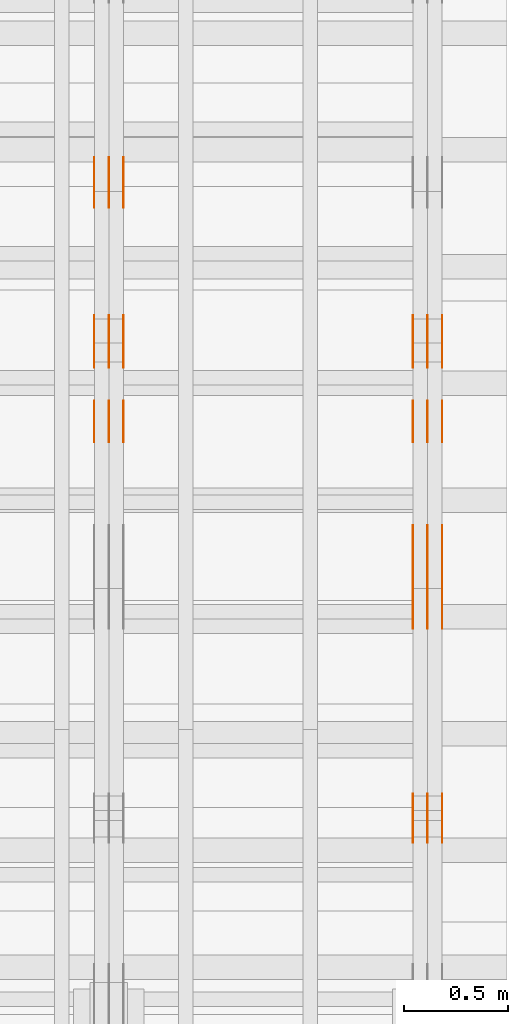
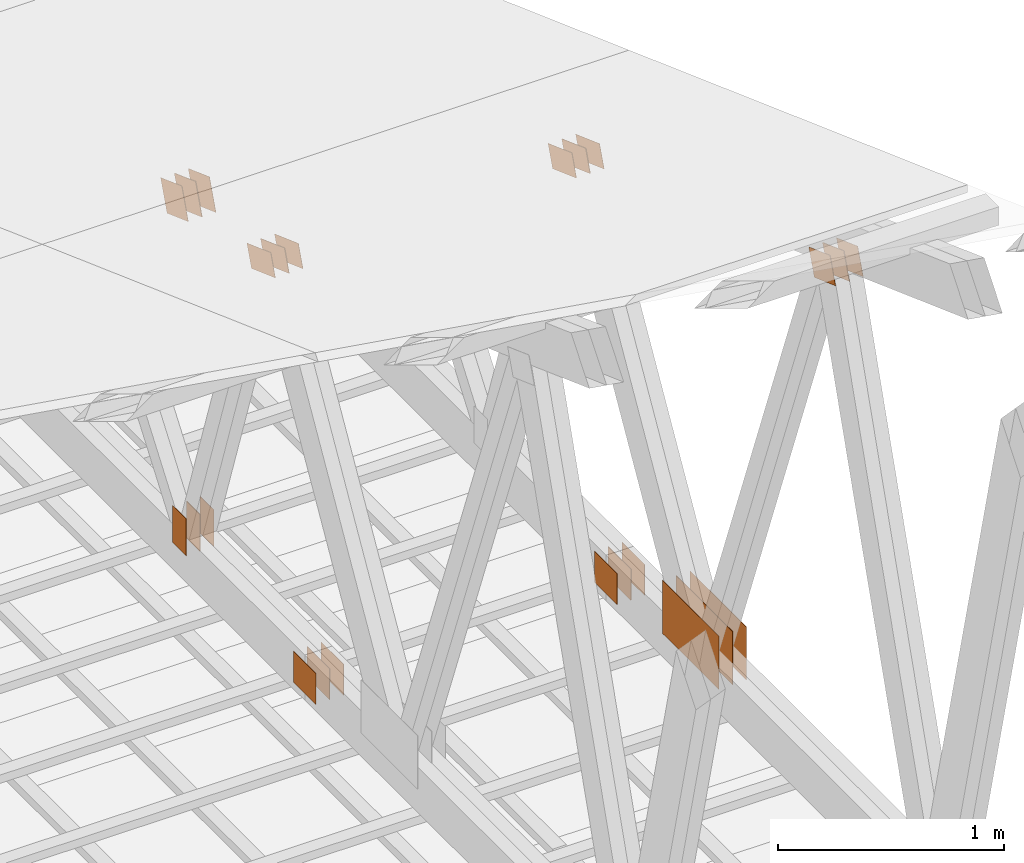
# One storey, part 175 of 189: 32 proxies.
"""IFC2X3 building model written with IfcOpenShell, lengths in millimetres."""

from ifc_helpers import new_model, entity, si_unit, converted_unit, derived_unit, direction, frame, origin, origin_2d_with_axis, place, context, subcontext, project, spatial, polyline, rectangle, outline, extrude, source, transform, mapped, material, type_object, type_shapes, element, save


model = new_model("IFC2X3")

# Units and contexts
model_context = context("Model", 3, precision=0.01, world=origin(), true_north=direction((6.12303176911189e-17, 1.0)))
body_context = subcontext(model_context, "Body", "Model", "MODEL_VIEW")
ifc_project = project(units=[si_unit("LENGTHUNIT", "METRE", prefix="MILLI"), si_unit("AREAUNIT", "SQUARE_METRE"), si_unit("VOLUMEUNIT", "CUBIC_METRE"), converted_unit("PLANEANGLEUNIT", "DEGREE", entity("IfcRatioMeasure", 0.0174532925199433), si_unit("PLANEANGLEUNIT", "RADIAN"), dimensions=[0, 0, 0, 0, 0, 0, 0]), si_unit("MASSUNIT", "GRAM", prefix="KILO"), derived_unit("MASSDENSITYUNIT", [(si_unit("MASSUNIT", "GRAM", prefix="KILO"), 1), (si_unit("LENGTHUNIT", "METRE"), -3)]), si_unit("TIMEUNIT", "SECOND"), si_unit("FREQUENCYUNIT", "HERTZ"), si_unit("THERMODYNAMICTEMPERATUREUNIT", "DEGREE_CELSIUS"), derived_unit("THERMALTRANSMITTANCEUNIT", [(si_unit("MASSUNIT", "GRAM", prefix="KILO"), 1), (si_unit("THERMODYNAMICTEMPERATUREUNIT", "KELVIN"), -1), (si_unit("TIMEUNIT", "SECOND"), -3)]), derived_unit("VOLUMETRICFLOWRATEUNIT", [(si_unit("LENGTHUNIT", "METRE"), 3), (si_unit("TIMEUNIT", "SECOND"), -1)]), si_unit("ELECTRICCURRENTUNIT", "AMPERE"), si_unit("ELECTRICVOLTAGEUNIT", "VOLT"), si_unit("POWERUNIT", "WATT"), si_unit("FORCEUNIT", "NEWTON"), si_unit("ILLUMINANCEUNIT", "LUX"), si_unit("LUMINOUSFLUXUNIT", "LUMEN"), si_unit("LUMINOUSINTENSITYUNIT", "CANDELA"), derived_unit("USERDEFINED", [(si_unit("MASSUNIT", "GRAM", prefix="KILO"), -1), (si_unit("LENGTHUNIT", "METRE"), -2), (si_unit("TIMEUNIT", "SECOND"), 3), (si_unit("LUMINOUSFLUXUNIT", "LUMEN"), 1)]), derived_unit("LINEARVELOCITYUNIT", [(si_unit("LENGTHUNIT", "METRE"), 1), (si_unit("TIMEUNIT", "SECOND"), -1)]), si_unit("PRESSUREUNIT", "PASCAL"), derived_unit("USERDEFINED", [(si_unit("LENGTHUNIT", "METRE"), -2), (si_unit("MASSUNIT", "GRAM", prefix="KILO"), 1), (si_unit("TIMEUNIT", "SECOND"), -2)])], contexts=[model_context])

# Site, building, storey
site_placement = place(None, origin())
site = spatial("IfcSite", under=ifc_project, at=site_placement, CompositionType="ELEMENT")
building_placement = place(site_placement, origin())
building = spatial("IfcBuilding", under=site, at=building_placement, CompositionType="ELEMENT")
storey_placement = place(building_placement, origin())
storey = spatial("IfcBuildingStorey", under=building, at=storey_placement, Name="Default", CompositionType="ELEMENT", Elevation=0.0)

# Proxies
ifc_material_1 = material(Name="IfcSurfaceStyle #280852")
building_element_proxy_type_1 = type_object("IfcBuildingElementProxyType", PredefinedType="NOTDEFINED", material=ifc_material_1)
shared_shape_1 = source(origin(), body_context, "Body", "SweptSolid", [
    extrude(outline(polyline([(-100.000279336925, -71.9999636698844), (100.000143005157, -71.9999636698844), (100.00004991978, 71.9999636698844), (-99.9999135880125, 71.9999636698845), (-100.000279336925, -71.9999636698844)])), frame((100.000143005157, 72.0001110824169, 0.0), z_axis=(0.0, 0.0, 1.0), x_axis=(-1.0, 0.0, 0.0)), (0.0, 0.0, 1.0), 1.3),
])
type_shapes(building_element_proxy_type_1, [shared_shape_1])
proxy_1_placement = place(building_placement, frame((49841.3, 21584.0819808932, 3071.51551466861), z_axis=(-1.0, 0.0, 0.0), x_axis=(0.0, 0.939692620785908, -0.342020143325669)))
element("IfcBuildingElementProxy", 1, at=proxy_1_placement, inside=storey, type_object=building_element_proxy_type_1, material=ifc_material_1, context=body_context, shape_type="MappedRepresentation", body=[
    mapped(shared_shape_1, transform((0.0, 0.0, 0.0), scale=1.0)),
])
ifc_material_2 = material(Name="IfcSurfaceStyle #280795")
building_element_proxy_type_2 = type_object("IfcBuildingElementProxyType", PredefinedType="NOTDEFINED", material=ifc_material_2)
shared_shape_2 = source(origin(), body_context, "Body", "SweptSolid", [
    extrude(outline(polyline([(-100.000279336925, -71.9999636698844), (100.000143005157, -71.9999636698844), (100.00004991978, 71.9999636698844), (-99.9999135880125, 71.9999636698845), (-100.000279336925, -71.9999636698844)])), frame((100.000143005157, 72.0001110824169, 0.0), z_axis=(0.0, 0.0, 1.0), x_axis=(-1.0, 0.0, 0.0)), (0.0, 0.0, 1.0), 1.29999999999998),
])
type_shapes(building_element_proxy_type_2, [shared_shape_2])
proxy_2_placement = place(building_placement, frame((49770.0, 21584.0819808932, 3071.51551466861), z_axis=(-1.0, 0.0, 0.0), x_axis=(0.0, 0.939692620785908, -0.342020143325669)))
element("IfcBuildingElementProxy", 2, at=proxy_2_placement, inside=storey, type_object=building_element_proxy_type_2, material=ifc_material_2, context=body_context, shape_type="MappedRepresentation", body=[
    mapped(shared_shape_2, transform((0.0, 0.0, 0.0), scale=1.0)),
])
ifc_material_3 = material(Name="IfcSurfaceStyle #280738")
building_element_proxy_type_3 = type_object("IfcBuildingElementProxyType", PredefinedType="NOTDEFINED", material=ifc_material_3)
shared_shape_3 = source(origin(), body_context, "Body", "SweptSolid", [
    extrude(outline(polyline([(-100.000279336925, -71.9999636698844), (100.000143005157, -71.9999636698844), (100.00004991978, 71.9999636698844), (-99.9999135880125, 71.9999636698845), (-100.000279336925, -71.9999636698844)])), frame((100.000143005157, 72.0001110824169, 0.0), z_axis=(0.0, 0.0, 1.0), x_axis=(-1.0, 0.0, 0.0)), (0.0, 0.0, 1.0), 1.29999999999998),
])
type_shapes(building_element_proxy_type_3, [shared_shape_3])
proxy_3_placement = place(building_placement, frame((49771.3, 21584.0819808932, 3071.51551466861), z_axis=(-1.0, 0.0, 0.0), x_axis=(0.0, 0.939692620785908, -0.342020143325669)))
element("IfcBuildingElementProxy", 3, at=proxy_3_placement, inside=storey, type_object=building_element_proxy_type_3, material=ifc_material_3, context=body_context, shape_type="MappedRepresentation", body=[
    mapped(shared_shape_3, transform((0.0, 0.0, 0.0), scale=1.0)),
])
ifc_material_4 = material(Name="IfcSurfaceStyle #280681")
building_element_proxy_type_4 = type_object("IfcBuildingElementProxyType", PredefinedType="NOTDEFINED", material=ifc_material_4)
shared_shape_4 = source(origin(), body_context, "Body", "SweptSolid", [
    extrude(outline(polyline([(-100.000279336925, -71.9999636698844), (100.000143005157, -71.9999636698844), (100.00004991978, 71.9999636698844), (-99.9999135880125, 71.9999636698845), (-100.000279336925, -71.9999636698844)])), frame((100.000143005157, 72.0001110824169, 0.0), z_axis=(0.0, 0.0, 1.0), x_axis=(-1.0, 0.0, 0.0)), (0.0, 0.0, 1.0), 1.29999999999999),
])
type_shapes(building_element_proxy_type_4, [shared_shape_4])
proxy_4_placement = place(building_placement, frame((49700.0, 21584.0819808932, 3071.51551466861), z_axis=(-1.0, 0.0, 0.0), x_axis=(0.0, 0.939692620785908, -0.342020143325669)))
element("IfcBuildingElementProxy", 4, at=proxy_4_placement, inside=storey, type_object=building_element_proxy_type_4, material=ifc_material_4, context=body_context, shape_type="MappedRepresentation", body=[
    mapped(shared_shape_4, transform((0.0, 0.0, 0.0), scale=1.0)),
])
ifc_material_5 = material(Name="IfcSurfaceStyle #280624")
building_element_proxy_type_5 = type_object("IfcBuildingElementProxyType", PredefinedType="NOTDEFINED", material=ifc_material_5)
shared_shape_5 = source(origin(), body_context, "Body", "SweptSolid", [
    extrude(rectangle(XDim=500.0, YDim=288.000007629395, at=origin_2d_with_axis()), frame((250.000021301719, 144.000006357829, 0.0), z_axis=(0.0, 0.0, 1.0), x_axis=(-1.0, 0.0, 0.0)), (0.0, 0.0, 1.0), 1.29999999999998),
])
type_shapes(building_element_proxy_type_5, [shared_shape_5])
proxy_5_placement = place(building_placement, frame((49841.3, 23069.1650603642, 127.333333333333), z_axis=(-1.0, 0.0, 0.0), x_axis=(0.0, -1.0, 0.0)))
element("IfcBuildingElementProxy", 5, at=proxy_5_placement, inside=storey, type_object=building_element_proxy_type_5, material=ifc_material_5, context=body_context, shape_type="MappedRepresentation", body=[
    mapped(shared_shape_5, transform((0.0, 0.0, 0.0), scale=1.0)),
])
ifc_material_6 = material(Name="IfcSurfaceStyle #280567")
building_element_proxy_type_6 = type_object("IfcBuildingElementProxyType", PredefinedType="NOTDEFINED", material=ifc_material_6)
shared_shape_6 = source(origin(), body_context, "Body", "SweptSolid", [
    extrude(rectangle(XDim=500.0, YDim=288.000007629395, at=origin_2d_with_axis()), frame((250.000021301719, 144.000006357829, 0.0), z_axis=(0.0, 0.0, 1.0), x_axis=(-1.0, 0.0, 0.0)), (0.0, 0.0, 1.0), 1.29999999999997),
])
type_shapes(building_element_proxy_type_6, [shared_shape_6])
proxy_6_placement = place(building_placement, frame((49770.0, 23069.1650603642, 127.333333333333), z_axis=(-1.0, 0.0, 0.0), x_axis=(0.0, -1.0, 0.0)))
element("IfcBuildingElementProxy", 6, at=proxy_6_placement, inside=storey, type_object=building_element_proxy_type_6, material=ifc_material_6, context=body_context, shape_type="MappedRepresentation", body=[
    mapped(shared_shape_6, transform((0.0, 0.0, 0.0), scale=1.0)),
])
ifc_material_7 = material(Name="IfcSurfaceStyle #280510")
building_element_proxy_type_7 = type_object("IfcBuildingElementProxyType", PredefinedType="NOTDEFINED", material=ifc_material_7)
shared_shape_7 = source(origin(), body_context, "Body", "SweptSolid", [
    extrude(rectangle(XDim=500.0, YDim=288.000007629395, at=origin_2d_with_axis()), frame((250.000021301719, 144.000006357829, 0.0), z_axis=(0.0, 0.0, 1.0), x_axis=(-1.0, 0.0, 0.0)), (0.0, 0.0, 1.0), 1.29999999999997),
])
type_shapes(building_element_proxy_type_7, [shared_shape_7])
proxy_7_placement = place(building_placement, frame((49771.3, 23069.1650603642, 127.333333333333), z_axis=(-1.0, 0.0, 0.0), x_axis=(0.0, -1.0, 0.0)))
element("IfcBuildingElementProxy", 7, at=proxy_7_placement, inside=storey, type_object=building_element_proxy_type_7, material=ifc_material_7, context=body_context, shape_type="MappedRepresentation", body=[
    mapped(shared_shape_7, transform((0.0, 0.0, 0.0), scale=1.0)),
])
ifc_material_8 = material(Name="IfcSurfaceStyle #280453")
building_element_proxy_type_8 = type_object("IfcBuildingElementProxyType", PredefinedType="NOTDEFINED", material=ifc_material_8)
shared_shape_8 = source(origin(), body_context, "Body", "SweptSolid", [
    extrude(rectangle(XDim=500.0, YDim=288.000007629395, at=origin_2d_with_axis()), frame((250.000021301719, 144.000006357829, 0.0), z_axis=(0.0, 0.0, 1.0), x_axis=(-1.0, 0.0, 0.0)), (0.0, 0.0, 1.0), 1.29999999999997),
])
type_shapes(building_element_proxy_type_8, [shared_shape_8])
proxy_8_placement = place(building_placement, frame((49700.0, 23069.1650603642, 127.333333333333), z_axis=(-1.0, 0.0, 0.0), x_axis=(0.0, -1.0, 0.0)))
element("IfcBuildingElementProxy", 8, at=proxy_8_placement, inside=storey, type_object=building_element_proxy_type_8, material=ifc_material_8, context=body_context, shape_type="MappedRepresentation", body=[
    mapped(shared_shape_8, transform((0.0, 0.0, 0.0), scale=1.0)),
])
ifc_material_9 = material(Name="IfcSurfaceStyle #280168")
building_element_proxy_type_9 = type_object("IfcBuildingElementProxyType", PredefinedType="NOTDEFINED", material=ifc_material_9)
shared_shape_9 = source(origin(), body_context, "Body", "SweptSolid", [
    extrude(outline(polyline([(-112.499846801582, -59.999986193028), (112.499924372729, -59.999986193028), (112.499888552087, 59.999986193028), (-112.499966123235, 59.999986193028), (-112.499846801582, -59.999986193028)])), frame((112.499989807712, 60.0001003787081, 0.0), z_axis=(0.0, 0.0, 1.0), x_axis=(-1.0, 0.0, 0.0)), (0.0, 0.0, 1.0), 1.3),
])
type_shapes(building_element_proxy_type_9, [shared_shape_9])
proxy_9_placement = place(building_placement, frame((49841.3, 24040.8868138992, 2049.61031693104), z_axis=(-1.0, 0.0, 0.0), x_axis=(0.0, -0.939692620785908, 0.342020143325669)))
element("IfcBuildingElementProxy", 9, at=proxy_9_placement, inside=storey, type_object=building_element_proxy_type_9, material=ifc_material_9, context=body_context, shape_type="MappedRepresentation", body=[
    mapped(shared_shape_9, transform((0.0, 0.0, 0.0), scale=1.0)),
])
ifc_material_10 = material(Name="IfcSurfaceStyle #280111")
building_element_proxy_type_10 = type_object("IfcBuildingElementProxyType", PredefinedType="NOTDEFINED", material=ifc_material_10)
shared_shape_10 = source(origin(), body_context, "Body", "SweptSolid", [
    extrude(outline(polyline([(-112.499846801582, -59.999986193028), (112.499924372729, -59.999986193028), (112.499888552087, 59.999986193028), (-112.499966123235, 59.999986193028), (-112.499846801582, -59.999986193028)])), frame((112.499989807712, 60.0001003787081, 0.0), z_axis=(0.0, 0.0, 1.0), x_axis=(-1.0, 0.0, 0.0)), (0.0, 0.0, 1.0), 1.29999999999998),
])
type_shapes(building_element_proxy_type_10, [shared_shape_10])
proxy_10_placement = place(building_placement, frame((49770.0, 24040.8868138992, 2049.61031693104), z_axis=(-1.0, 0.0, 0.0), x_axis=(0.0, -0.939692620785908, 0.342020143325669)))
element("IfcBuildingElementProxy", 10, at=proxy_10_placement, inside=storey, type_object=building_element_proxy_type_10, material=ifc_material_10, context=body_context, shape_type="MappedRepresentation", body=[
    mapped(shared_shape_10, transform((0.0, 0.0, 0.0), scale=1.0)),
])
ifc_material_11 = material(Name="IfcSurfaceStyle #280054")
building_element_proxy_type_11 = type_object("IfcBuildingElementProxyType", PredefinedType="NOTDEFINED", material=ifc_material_11)
shared_shape_11 = source(origin(), body_context, "Body", "SweptSolid", [
    extrude(outline(polyline([(-112.499846801582, -59.999986193028), (112.499924372729, -59.999986193028), (112.499888552087, 59.999986193028), (-112.499966123235, 59.999986193028), (-112.499846801582, -59.999986193028)])), frame((112.499989807712, 60.0001003787081, 0.0), z_axis=(0.0, 0.0, 1.0), x_axis=(-1.0, 0.0, 0.0)), (0.0, 0.0, 1.0), 1.29999999999998),
])
type_shapes(building_element_proxy_type_11, [shared_shape_11])
proxy_11_placement = place(building_placement, frame((49771.3, 24040.8868138992, 2049.61031693104), z_axis=(-1.0, 0.0, 0.0), x_axis=(0.0, -0.939692620785908, 0.342020143325669)))
element("IfcBuildingElementProxy", 11, at=proxy_11_placement, inside=storey, type_object=building_element_proxy_type_11, material=ifc_material_11, context=body_context, shape_type="MappedRepresentation", body=[
    mapped(shared_shape_11, transform((0.0, 0.0, 0.0), scale=1.0)),
])
ifc_material_12 = material(Name="IfcSurfaceStyle #279997")
building_element_proxy_type_12 = type_object("IfcBuildingElementProxyType", PredefinedType="NOTDEFINED", material=ifc_material_12)
shared_shape_12 = source(origin(), body_context, "Body", "SweptSolid", [
    extrude(outline(polyline([(-112.499846801582, -59.999986193028), (112.499924372729, -59.999986193028), (112.499888552087, 59.999986193028), (-112.499966123235, 59.999986193028), (-112.499846801582, -59.999986193028)])), frame((112.499989807712, 60.0001003787081, 0.0), z_axis=(0.0, 0.0, 1.0), x_axis=(-1.0, 0.0, 0.0)), (0.0, 0.0, 1.0), 1.29999999999999),
])
type_shapes(building_element_proxy_type_12, [shared_shape_12])
proxy_12_placement = place(building_placement, frame((49700.0, 24040.8868138992, 2049.61031693104), z_axis=(-1.0, 0.0, 0.0), x_axis=(0.0, -0.939692620785908, 0.342020143325669)))
element("IfcBuildingElementProxy", 12, at=proxy_12_placement, inside=storey, type_object=building_element_proxy_type_12, material=ifc_material_12, context=body_context, shape_type="MappedRepresentation", body=[
    mapped(shared_shape_12, transform((0.0, 0.0, 0.0), scale=1.0)),
])
ifc_material_13 = material(Name="IfcSurfaceStyle #276292")
building_element_proxy_type_13 = type_object("IfcBuildingElementProxyType", PredefinedType="NOTDEFINED", material=ifc_material_13)
shared_shape_13 = source(origin(), body_context, "Body", "SweptSolid", [
    extrude(rectangle(XDim=200.0, YDim=168.0, at=origin_2d_with_axis()), frame((100.0, 84.0, 0.0), z_axis=(0.0, 0.0, 1.0), x_axis=(-1.0, 0.0, 0.0)), (0.0, 0.0, 1.0), 1.3),
])
type_shapes(building_element_proxy_type_13, [shared_shape_13])
proxy_13_placement = place(building_placement, frame((49841.3, 23470.0, 206.5), z_axis=(-1.0, 0.0, 0.0), x_axis=(0.0, 1.0, 0.0)))
element("IfcBuildingElementProxy", 13, at=proxy_13_placement, inside=storey, type_object=building_element_proxy_type_13, material=ifc_material_13, context=body_context, shape_type="MappedRepresentation", body=[
    mapped(shared_shape_13, transform((0.0, 0.0, 0.0), scale=1.0)),
])
ifc_material_14 = material(Name="IfcSurfaceStyle #276235")
building_element_proxy_type_14 = type_object("IfcBuildingElementProxyType", PredefinedType="NOTDEFINED", material=ifc_material_14)
shared_shape_14 = source(origin(), body_context, "Body", "SweptSolid", [
    extrude(rectangle(XDim=200.0, YDim=168.0, at=origin_2d_with_axis()), frame((100.0, 84.0, 0.0), z_axis=(0.0, 0.0, 1.0), x_axis=(-1.0, 0.0, 0.0)), (0.0, 0.0, 1.0), 1.29999999999998),
])
type_shapes(building_element_proxy_type_14, [shared_shape_14])
proxy_14_placement = place(building_placement, frame((49770.0, 23470.0, 206.5), z_axis=(-1.0, 0.0, 0.0), x_axis=(0.0, 1.0, 0.0)))
element("IfcBuildingElementProxy", 14, at=proxy_14_placement, inside=storey, type_object=building_element_proxy_type_14, material=ifc_material_14, context=body_context, shape_type="MappedRepresentation", body=[
    mapped(shared_shape_14, transform((0.0, 0.0, 0.0), scale=1.0)),
])
ifc_material_15 = material(Name="IfcSurfaceStyle #276178")
building_element_proxy_type_15 = type_object("IfcBuildingElementProxyType", PredefinedType="NOTDEFINED", material=ifc_material_15)
shared_shape_15 = source(origin(), body_context, "Body", "SweptSolid", [
    extrude(rectangle(XDim=200.0, YDim=168.0, at=origin_2d_with_axis()), frame((100.0, 84.0, 0.0), z_axis=(0.0, 0.0, 1.0), x_axis=(-1.0, 0.0, 0.0)), (0.0, 0.0, 1.0), 1.29999999999998),
])
type_shapes(building_element_proxy_type_15, [shared_shape_15])
proxy_15_placement = place(building_placement, frame((49771.3, 23470.0, 206.5), z_axis=(-1.0, 0.0, 0.0), x_axis=(0.0, 1.0, 0.0)))
element("IfcBuildingElementProxy", 15, at=proxy_15_placement, inside=storey, type_object=building_element_proxy_type_15, material=ifc_material_15, context=body_context, shape_type="MappedRepresentation", body=[
    mapped(shared_shape_15, transform((0.0, 0.0, 0.0), scale=1.0)),
])
ifc_material_16 = material(Name="IfcSurfaceStyle #276121")
building_element_proxy_type_16 = type_object("IfcBuildingElementProxyType", PredefinedType="NOTDEFINED", material=ifc_material_16)
shared_shape_16 = source(origin(), body_context, "Body", "SweptSolid", [
    extrude(rectangle(XDim=200.0, YDim=168.0, at=origin_2d_with_axis()), frame((100.0, 84.0, 0.0), z_axis=(0.0, 0.0, 1.0), x_axis=(-1.0, 0.0, 0.0)), (0.0, 0.0, 1.0), 1.29999999999999),
])
type_shapes(building_element_proxy_type_16, [shared_shape_16])
proxy_16_placement = place(building_placement, frame((49700.0, 23470.0, 206.5), z_axis=(-1.0, 0.0, 0.0), x_axis=(0.0, 1.0, 0.0)))
element("IfcBuildingElementProxy", 16, at=proxy_16_placement, inside=storey, type_object=building_element_proxy_type_16, material=ifc_material_16, context=body_context, shape_type="MappedRepresentation", body=[
    mapped(shared_shape_16, transform((0.0, 0.0, 0.0), scale=1.0)),
])
ifc_material_17 = material(Name="IfcSurfaceStyle #264378")
building_element_proxy_type_17 = type_object("IfcBuildingElementProxyType", PredefinedType="NOTDEFINED", material=ifc_material_17)
shared_shape_17 = source(origin(), body_context, "Body", "SweptSolid", [
    extrude(outline(polyline([(-112.499846801582, -59.999986193028), (112.499924372729, -59.999986193028), (112.499888552087, 59.999986193028), (-112.499966123235, 59.999986193028), (-112.499846801582, -59.999986193028)])), frame((112.499989807712, 60.0001003787081, 0.0), z_axis=(0.0, 0.0, 1.0), x_axis=(-1.0, 0.0, 0.0)), (0.0, 0.0, 1.0), 1.3),
])
type_shapes(building_element_proxy_type_17, [shared_shape_17])
proxy_17_placement = place(building_placement, frame((48301.3, 24040.8868138992, 2049.61031693104), z_axis=(-1.0, 0.0, 0.0), x_axis=(0.0, -0.939692620785908, 0.342020143325669)))
element("IfcBuildingElementProxy", 17, at=proxy_17_placement, inside=storey, type_object=building_element_proxy_type_17, material=ifc_material_17, context=body_context, shape_type="MappedRepresentation", body=[
    mapped(shared_shape_17, transform((0.0, 0.0, 0.0), scale=1.0)),
])
ifc_material_18 = material(Name="IfcSurfaceStyle #264321")
building_element_proxy_type_18 = type_object("IfcBuildingElementProxyType", PredefinedType="NOTDEFINED", material=ifc_material_18)
shared_shape_18 = source(origin(), body_context, "Body", "SweptSolid", [
    extrude(outline(polyline([(-112.499846801582, -59.999986193028), (112.499924372729, -59.999986193028), (112.499888552087, 59.999986193028), (-112.499966123235, 59.999986193028), (-112.499846801582, -59.999986193028)])), frame((112.499989807712, 60.0001003787081, 0.0), z_axis=(0.0, 0.0, 1.0), x_axis=(-1.0, 0.0, 0.0)), (0.0, 0.0, 1.0), 1.29999999999998),
])
type_shapes(building_element_proxy_type_18, [shared_shape_18])
proxy_18_placement = place(building_placement, frame((48230.0, 24040.8868138992, 2049.61031693104), z_axis=(-1.0, 0.0, 0.0), x_axis=(0.0, -0.939692620785908, 0.342020143325669)))
element("IfcBuildingElementProxy", 18, at=proxy_18_placement, inside=storey, type_object=building_element_proxy_type_18, material=ifc_material_18, context=body_context, shape_type="MappedRepresentation", body=[
    mapped(shared_shape_18, transform((0.0, 0.0, 0.0), scale=1.0)),
])
ifc_material_19 = material(Name="IfcSurfaceStyle #264264")
building_element_proxy_type_19 = type_object("IfcBuildingElementProxyType", PredefinedType="NOTDEFINED", material=ifc_material_19)
shared_shape_19 = source(origin(), body_context, "Body", "SweptSolid", [
    extrude(outline(polyline([(-112.499846801582, -59.999986193028), (112.499924372729, -59.999986193028), (112.499888552087, 59.999986193028), (-112.499966123235, 59.999986193028), (-112.499846801582, -59.999986193028)])), frame((112.499989807712, 60.0001003787081, 0.0), z_axis=(0.0, 0.0, 1.0), x_axis=(-1.0, 0.0, 0.0)), (0.0, 0.0, 1.0), 1.29999999999998),
])
type_shapes(building_element_proxy_type_19, [shared_shape_19])
proxy_19_placement = place(building_placement, frame((48231.3, 24040.8868138992, 2049.61031693104), z_axis=(-1.0, 0.0, 0.0), x_axis=(0.0, -0.939692620785908, 0.342020143325669)))
element("IfcBuildingElementProxy", 19, at=proxy_19_placement, inside=storey, type_object=building_element_proxy_type_19, material=ifc_material_19, context=body_context, shape_type="MappedRepresentation", body=[
    mapped(shared_shape_19, transform((0.0, 0.0, 0.0), scale=1.0)),
])
ifc_material_20 = material(Name="IfcSurfaceStyle #264207")
building_element_proxy_type_20 = type_object("IfcBuildingElementProxyType", PredefinedType="NOTDEFINED", material=ifc_material_20)
shared_shape_20 = source(origin(), body_context, "Body", "SweptSolid", [
    extrude(outline(polyline([(-112.499846801582, -59.999986193028), (112.499924372729, -59.999986193028), (112.499888552087, 59.999986193028), (-112.499966123235, 59.999986193028), (-112.499846801582, -59.999986193028)])), frame((112.499989807712, 60.0001003787081, 0.0), z_axis=(0.0, 0.0, 1.0), x_axis=(-1.0, 0.0, 0.0)), (0.0, 0.0, 1.0), 1.29999999999999),
])
type_shapes(building_element_proxy_type_20, [shared_shape_20])
proxy_20_placement = place(building_placement, frame((48160.0, 24040.8868138992, 2049.61031693104), z_axis=(-1.0, 0.0, 0.0), x_axis=(0.0, -0.939692620785908, 0.342020143325669)))
element("IfcBuildingElementProxy", 20, at=proxy_20_placement, inside=storey, type_object=building_element_proxy_type_20, material=ifc_material_20, context=body_context, shape_type="MappedRepresentation", body=[
    mapped(shared_shape_20, transform((0.0, 0.0, 0.0), scale=1.0)),
])
ifc_material_21 = material(Name="IfcSurfaceStyle #264150")
building_element_proxy_type_21 = type_object("IfcBuildingElementProxyType", PredefinedType="NOTDEFINED", material=ifc_material_21)
shared_shape_21 = source(origin(), body_context, "Body", "SweptSolid", [
    extrude(rectangle(XDim=200.0, YDim=120.0, at=origin_2d_with_axis()), frame((100.0, 60.0002296775929, 0.0), z_axis=(0.0, 0.0, 1.0), x_axis=(-1.0, 0.0, 0.0)), (0.0, 0.0, 1.0), 1.3),
])
type_shapes(building_element_proxy_type_21, [shared_shape_21])
proxy_21_placement = place(building_placement, frame((48301.3, 24619.3435203224, 145.0), z_axis=(-1.0, 0.0, 0.0), x_axis=(0.0, 0.0, 1.0)))
element("IfcBuildingElementProxy", 21, at=proxy_21_placement, inside=storey, type_object=building_element_proxy_type_21, material=ifc_material_21, context=body_context, shape_type="MappedRepresentation", body=[
    mapped(shared_shape_21, transform((0.0, 0.0, 0.0), scale=1.0)),
])
ifc_material_22 = material(Name="IfcSurfaceStyle #264093")
building_element_proxy_type_22 = type_object("IfcBuildingElementProxyType", PredefinedType="NOTDEFINED", material=ifc_material_22)
shared_shape_22 = source(origin(), body_context, "Body", "SweptSolid", [
    extrude(rectangle(XDim=200.0, YDim=120.0, at=origin_2d_with_axis()), frame((100.0, 60.0002296775929, 0.0), z_axis=(0.0, 0.0, 1.0), x_axis=(-1.0, 0.0, 0.0)), (0.0, 0.0, 1.0), 1.29999999999998),
])
type_shapes(building_element_proxy_type_22, [shared_shape_22])
proxy_22_placement = place(building_placement, frame((48230.0, 24619.3435203224, 145.0), z_axis=(-1.0, 0.0, 0.0), x_axis=(0.0, 0.0, 1.0)))
element("IfcBuildingElementProxy", 22, at=proxy_22_placement, inside=storey, type_object=building_element_proxy_type_22, material=ifc_material_22, context=body_context, shape_type="MappedRepresentation", body=[
    mapped(shared_shape_22, transform((0.0, 0.0, 0.0), scale=1.0)),
])
ifc_material_23 = material(Name="IfcSurfaceStyle #264036")
building_element_proxy_type_23 = type_object("IfcBuildingElementProxyType", PredefinedType="NOTDEFINED", material=ifc_material_23)
shared_shape_23 = source(origin(), body_context, "Body", "SweptSolid", [
    extrude(rectangle(XDim=200.0, YDim=120.0, at=origin_2d_with_axis()), frame((100.0, 60.0002296775929, 0.0), z_axis=(0.0, 0.0, 1.0), x_axis=(-1.0, 0.0, 0.0)), (0.0, 0.0, 1.0), 1.29999999999998),
])
type_shapes(building_element_proxy_type_23, [shared_shape_23])
proxy_23_placement = place(building_placement, frame((48231.3, 24619.3435203224, 145.0), z_axis=(-1.0, 0.0, 0.0), x_axis=(0.0, 0.0, 1.0)))
element("IfcBuildingElementProxy", 23, at=proxy_23_placement, inside=storey, type_object=building_element_proxy_type_23, material=ifc_material_23, context=body_context, shape_type="MappedRepresentation", body=[
    mapped(shared_shape_23, transform((0.0, 0.0, 0.0), scale=1.0)),
])
ifc_material_24 = material(Name="IfcSurfaceStyle #263979")
building_element_proxy_type_24 = type_object("IfcBuildingElementProxyType", PredefinedType="NOTDEFINED", material=ifc_material_24)
shared_shape_24 = source(origin(), body_context, "Body", "SweptSolid", [
    extrude(rectangle(XDim=200.0, YDim=120.0, at=origin_2d_with_axis()), frame((100.0, 60.0002296775929, 0.0), z_axis=(0.0, 0.0, 1.0), x_axis=(-1.0, 0.0, 0.0)), (0.0, 0.0, 1.0), 1.29999999999999),
])
type_shapes(building_element_proxy_type_24, [shared_shape_24])
proxy_24_placement = place(building_placement, frame((48160.0, 24619.3435203224, 145.0), z_axis=(-1.0, 0.0, 0.0), x_axis=(0.0, 0.0, 1.0)))
element("IfcBuildingElementProxy", 24, at=proxy_24_placement, inside=storey, type_object=building_element_proxy_type_24, material=ifc_material_24, context=body_context, shape_type="MappedRepresentation", body=[
    mapped(shared_shape_24, transform((0.0, 0.0, 0.0), scale=1.0)),
])
ifc_material_25 = material(Name="IfcSurfaceStyle #260502")
building_element_proxy_type_25 = type_object("IfcBuildingElementProxyType", PredefinedType="NOTDEFINED", material=ifc_material_25)
shared_shape_25 = source(origin(), body_context, "Body", "SweptSolid", [
    extrude(rectangle(XDim=200.0, YDim=168.0, at=origin_2d_with_axis()), frame((100.0, 84.0, 0.0), z_axis=(0.0, 0.0, 1.0), x_axis=(-1.0, 0.0, 0.0)), (0.0, 0.0, 1.0), 1.3),
])
type_shapes(building_element_proxy_type_25, [shared_shape_25])
proxy_25_placement = place(building_placement, frame((48301.3, 23470.0, 206.5), z_axis=(-1.0, 0.0, 0.0), x_axis=(0.0, 1.0, 0.0)))
element("IfcBuildingElementProxy", 25, at=proxy_25_placement, inside=storey, type_object=building_element_proxy_type_25, material=ifc_material_25, context=body_context, shape_type="MappedRepresentation", body=[
    mapped(shared_shape_25, transform((0.0, 0.0, 0.0), scale=1.0)),
])
ifc_material_26 = material(Name="IfcSurfaceStyle #260445")
building_element_proxy_type_26 = type_object("IfcBuildingElementProxyType", PredefinedType="NOTDEFINED", material=ifc_material_26)
shared_shape_26 = source(origin(), body_context, "Body", "SweptSolid", [
    extrude(rectangle(XDim=200.0, YDim=168.0, at=origin_2d_with_axis()), frame((100.0, 84.0, 0.0), z_axis=(0.0, 0.0, 1.0), x_axis=(-1.0, 0.0, 0.0)), (0.0, 0.0, 1.0), 1.29999999999998),
])
type_shapes(building_element_proxy_type_26, [shared_shape_26])
proxy_26_placement = place(building_placement, frame((48230.0, 23470.0, 206.5), z_axis=(-1.0, 0.0, 0.0), x_axis=(0.0, 1.0, 0.0)))
element("IfcBuildingElementProxy", 26, at=proxy_26_placement, inside=storey, type_object=building_element_proxy_type_26, material=ifc_material_26, context=body_context, shape_type="MappedRepresentation", body=[
    mapped(shared_shape_26, transform((0.0, 0.0, 0.0), scale=1.0)),
])
ifc_material_27 = material(Name="IfcSurfaceStyle #260388")
building_element_proxy_type_27 = type_object("IfcBuildingElementProxyType", PredefinedType="NOTDEFINED", material=ifc_material_27)
shared_shape_27 = source(origin(), body_context, "Body", "SweptSolid", [
    extrude(rectangle(XDim=200.0, YDim=168.0, at=origin_2d_with_axis()), frame((100.0, 84.0, 0.0), z_axis=(0.0, 0.0, 1.0), x_axis=(-1.0, 0.0, 0.0)), (0.0, 0.0, 1.0), 1.29999999999998),
])
type_shapes(building_element_proxy_type_27, [shared_shape_27])
proxy_27_placement = place(building_placement, frame((48231.3, 23470.0, 206.5), z_axis=(-1.0, 0.0, 0.0), x_axis=(0.0, 1.0, 0.0)))
element("IfcBuildingElementProxy", 27, at=proxy_27_placement, inside=storey, type_object=building_element_proxy_type_27, material=ifc_material_27, context=body_context, shape_type="MappedRepresentation", body=[
    mapped(shared_shape_27, transform((0.0, 0.0, 0.0), scale=1.0)),
])
ifc_material_28 = material(Name="IfcSurfaceStyle #260331")
building_element_proxy_type_28 = type_object("IfcBuildingElementProxyType", PredefinedType="NOTDEFINED", material=ifc_material_28)
shared_shape_28 = source(origin(), body_context, "Body", "SweptSolid", [
    extrude(rectangle(XDim=200.0, YDim=168.0, at=origin_2d_with_axis()), frame((100.0, 84.0, 0.0), z_axis=(0.0, 0.0, 1.0), x_axis=(-1.0, 0.0, 0.0)), (0.0, 0.0, 1.0), 1.29999999999999),
])
type_shapes(building_element_proxy_type_28, [shared_shape_28])
proxy_28_placement = place(building_placement, frame((48160.0, 23470.0, 206.5), z_axis=(-1.0, 0.0, 0.0), x_axis=(0.0, 1.0, 0.0)))
element("IfcBuildingElementProxy", 28, at=proxy_28_placement, inside=storey, type_object=building_element_proxy_type_28, material=ifc_material_28, context=body_context, shape_type="MappedRepresentation", body=[
    mapped(shared_shape_28, transform((0.0, 0.0, 0.0), scale=1.0)),
])
ifc_material_29 = material(Name="IfcSurfaceStyle #258342")
building_element_proxy_type_29 = type_object("IfcBuildingElementProxyType", PredefinedType="NOTDEFINED", material=ifc_material_29)
shared_shape_29 = source(origin(), body_context, "Body", "SweptSolid", [
    extrude(outline(polyline([(-99.9999065788418, -84.0000755647729), (99.9999734279406, -84.0000755647729), (99.9999483293475, 84.000075564773), (-100.000015178446, 84.000075564773), (-99.9999065788418, -84.0000755647729)])), frame((100.000157783747, 84.0001144608011, 0.0), z_axis=(0.0, 0.0, 1.0), x_axis=(-1.0, 0.0, 0.0)), (0.0, 0.0, 1.0), 1.3),
])
type_shapes(building_element_proxy_type_29, [shared_shape_29])
proxy_29_placement = place(building_placement, frame((48301.3, 24788.4767593228, 1895.10136879206), z_axis=(-1.0, 0.0, 0.0), x_axis=(0.0, -0.939692620785908, 0.342020143325669)))
element("IfcBuildingElementProxy", 29, at=proxy_29_placement, inside=storey, type_object=building_element_proxy_type_29, material=ifc_material_29, context=body_context, shape_type="MappedRepresentation", body=[
    mapped(shared_shape_29, transform((0.0, 0.0, 0.0), scale=1.0)),
])
ifc_material_30 = material(Name="IfcSurfaceStyle #258285")
building_element_proxy_type_30 = type_object("IfcBuildingElementProxyType", PredefinedType="NOTDEFINED", material=ifc_material_30)
shared_shape_30 = source(origin(), body_context, "Body", "SweptSolid", [
    extrude(outline(polyline([(-99.9999065788418, -84.0000755647729), (99.9999734279406, -84.0000755647729), (99.9999483293475, 84.000075564773), (-100.000015178446, 84.000075564773), (-99.9999065788418, -84.0000755647729)])), frame((100.000157783747, 84.0001144608011, 0.0), z_axis=(0.0, 0.0, 1.0), x_axis=(-1.0, 0.0, 0.0)), (0.0, 0.0, 1.0), 1.29999999999998),
])
type_shapes(building_element_proxy_type_30, [shared_shape_30])
proxy_30_placement = place(building_placement, frame((48230.0, 24788.4767593228, 1895.10136879206), z_axis=(-1.0, 0.0, 0.0), x_axis=(0.0, -0.939692620785908, 0.342020143325669)))
element("IfcBuildingElementProxy", 30, at=proxy_30_placement, inside=storey, type_object=building_element_proxy_type_30, material=ifc_material_30, context=body_context, shape_type="MappedRepresentation", body=[
    mapped(shared_shape_30, transform((0.0, 0.0, 0.0), scale=1.0)),
])
ifc_material_31 = material(Name="IfcSurfaceStyle #258228")
building_element_proxy_type_31 = type_object("IfcBuildingElementProxyType", PredefinedType="NOTDEFINED", material=ifc_material_31)
shared_shape_31 = source(origin(), body_context, "Body", "SweptSolid", [
    extrude(outline(polyline([(-99.9999065788418, -84.0000755647729), (99.9999734279406, -84.0000755647729), (99.9999483293475, 84.000075564773), (-100.000015178446, 84.000075564773), (-99.9999065788418, -84.0000755647729)])), frame((100.000157783747, 84.0001144608011, 0.0), z_axis=(0.0, 0.0, 1.0), x_axis=(-1.0, 0.0, 0.0)), (0.0, 0.0, 1.0), 1.29999999999998),
])
type_shapes(building_element_proxy_type_31, [shared_shape_31])
proxy_31_placement = place(building_placement, frame((48231.3, 24788.4767593228, 1895.10136879206), z_axis=(-1.0, 0.0, 0.0), x_axis=(0.0, -0.939692620785908, 0.342020143325669)))
element("IfcBuildingElementProxy", 31, at=proxy_31_placement, inside=storey, type_object=building_element_proxy_type_31, material=ifc_material_31, context=body_context, shape_type="MappedRepresentation", body=[
    mapped(shared_shape_31, transform((0.0, 0.0, 0.0), scale=1.0)),
])
ifc_material_32 = material(Name="IfcSurfaceStyle #258171")
building_element_proxy_type_32 = type_object("IfcBuildingElementProxyType", PredefinedType="NOTDEFINED", material=ifc_material_32)
shared_shape_32 = source(origin(), body_context, "Body", "SweptSolid", [
    extrude(outline(polyline([(-99.9999065788418, -84.0000755647729), (99.9999734279406, -84.0000755647729), (99.9999483293475, 84.000075564773), (-100.000015178446, 84.000075564773), (-99.9999065788418, -84.0000755647729)])), frame((100.000157783747, 84.0001144608011, 0.0), z_axis=(0.0, 0.0, 1.0), x_axis=(-1.0, 0.0, 0.0)), (0.0, 0.0, 1.0), 1.29999999999999),
])
type_shapes(building_element_proxy_type_32, [shared_shape_32])
proxy_32_placement = place(building_placement, frame((48160.0, 24788.4767593228, 1895.10136879206), z_axis=(-1.0, 0.0, 0.0), x_axis=(0.0, -0.939692620785908, 0.342020143325669)))
element("IfcBuildingElementProxy", 32, at=proxy_32_placement, inside=storey, type_object=building_element_proxy_type_32, material=ifc_material_32, context=body_context, shape_type="MappedRepresentation", body=[
    mapped(shared_shape_32, transform((0.0, 0.0, 0.0), scale=1.0)),
])

save(model, "model.ifc")
